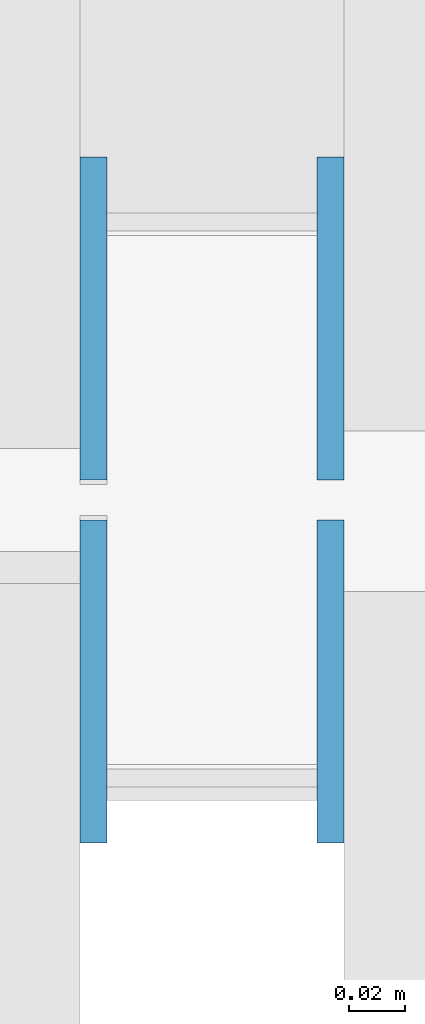
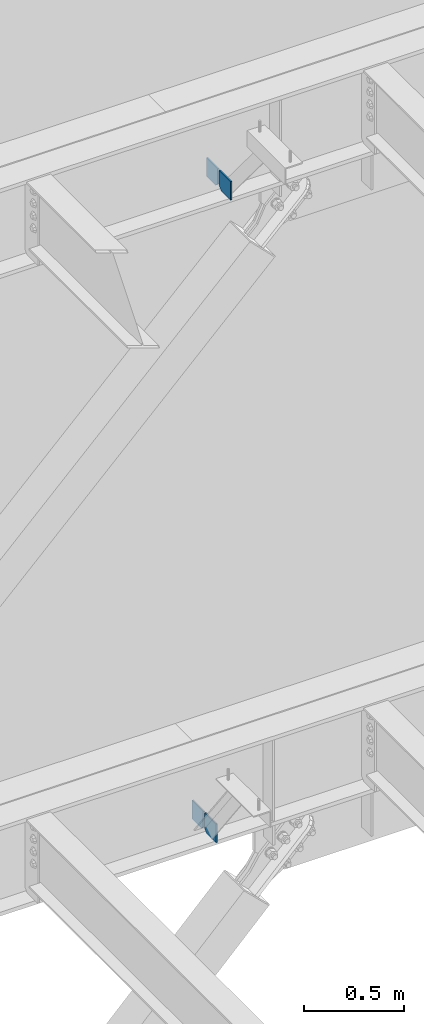
# One storey, part 516 of 1179: 4 columns, 2 elements without a shape of their own.
"""IFC2X3 building model written with IfcOpenShell, lengths in millimetres."""

from ifc_helpers import new_model, si_unit, frame, origin_with_axes, place, context, subcontext, project, spatial, faceted_brep, material, type_object, element, aggregate, save


model = new_model("IFC2X3")

# Units and contexts
model_context = context("Model", 3, precision=1e-05, world=origin_with_axes())
body_context = subcontext(model_context, "Body", "Model", "MODEL_VIEW")
ifc_project = project(units=[si_unit("LENGTHUNIT", "METRE", prefix="MILLI"), si_unit("AREAUNIT", "SQUARE_METRE"), si_unit("VOLUMEUNIT", "CUBIC_METRE"), si_unit("MASSUNIT", "GRAM", prefix="KILO"), si_unit("TIMEUNIT", "SECOND"), si_unit("PLANEANGLEUNIT", "RADIAN"), si_unit("SOLIDANGLEUNIT", "STERADIAN"), si_unit("THERMODYNAMICTEMPERATUREUNIT", "DEGREE_CELSIUS"), si_unit("LUMINOUSINTENSITYUNIT", "LUMEN")], contexts=[model_context])

# Site, building, storey
site_placement = place(None, origin_with_axes())
site = spatial("IfcSite", under=ifc_project, at=site_placement, CompositionType="ELEMENT")
building_placement = place(site_placement, origin_with_axes())
building = spatial("IfcBuilding", under=site, at=building_placement, Name="Undefined", CompositionType="ELEMENT")
storey_placement = place(building_placement, origin_with_axes())
storey = spatial("IfcBuildingStorey", under=building, at=storey_placement, Name="Undefined", CompositionType="ELEMENT", Elevation=0.0)

# Assembly, columns
assembly_1_placement = place(storey_placement, origin_with_axes())
assembly_1 = element("IfcElementAssembly", 1, at=assembly_1_placement, inside=storey, Name="BEAM", AssemblyPlace="NOTDEFINED", PredefinedType="RIGID_FRAME")
ifc_material = material(Name="STEEL/A36")
column_type = type_object("IfcColumnType", PredefinedType="NOTDEFINED")
column_1_placement = place(assembly_1_placement, frame((3530.36728739681, 41263.09375, 7488.2375), z_axis=(0.0, -1.0, 0.0), x_axis=(0.0, 0.0, 1.0)))
column_1 = element("IfcColumn", 2, at=column_1_placement, type_object=column_type, material=ifc_material, Name="PLATE", context=body_context, shape_type="Brep", body=[
    faceted_brep([(22.2250000000004, 4.76250000000073, 57.1500000000015), (0.0, 4.76250000000073, 34.9249999999993), (0.0, -4.76250000000073, 34.9249999999993), (22.2250000000004, -4.76250000000073, 57.1500000000015), (114.300000000001, 4.76250000000073, 57.1500000000015), (114.300000000001, 4.76250000000073, -57.1500000000015), (0.0, 4.76250000000073, -57.1500000000015), (114.300000000001, -4.76250000000073, 57.1500000000015), (0.0, -4.76250000000073, -57.1500000000015), (114.300000000001, -4.76250000000073, -57.1500000000015)], [[[0, 1, 2, 3]], [[4, 5, 6, 1, 0]], [[7, 4, 0, 3]], [[8, 9, 7, 3, 2]], [[8, 6, 5, 9]], [[7, 9, 5, 4]], [[6, 8, 2, 1]]]),
])
column_2_placement = place(assembly_1_placement, frame((3530.36728739681, 41134.50625, 7488.2375), z_axis=(0.0, 1.0, 0.0), x_axis=(0.0, 0.0, 1.0)))
column_2 = element("IfcColumn", 3, at=column_2_placement, type_object=column_type, material=ifc_material, Name="PLATE", context=body_context, shape_type="Brep", body=[
    faceted_brep([(22.2250000000004, 4.76250000000073, 57.1500000000015), (0.0, 4.76250000000073, 34.9249999999993), (0.0, -4.76250000000073, 34.9249999999993), (22.2250000000004, -4.76250000000073, 57.1500000000015), (114.300000000001, 4.76250000000073, 57.1500000000015), (114.300000000001, 4.76250000000073, -57.1500000000015), (0.0, 4.76250000000073, -57.1500000000015), (114.300000000001, -4.76250000000073, 57.1500000000015), (0.0, -4.76250000000073, -57.1500000000015), (114.300000000001, -4.76250000000073, -57.1500000000015)], [[[0, 1, 2, 3]], [[4, 5, 6, 1, 0]], [[7, 4, 0, 3]], [[8, 9, 7, 3, 2]], [[8, 6, 5, 9]], [[7, 9, 5, 4]], [[6, 8, 2, 1]]]),
])
aggregate(assembly_1, [column_1, column_2])

assembly_2_placement = place(storey_placement, origin_with_axes())
assembly_2 = element("IfcElementAssembly", 4, at=assembly_2_placement, inside=storey, Name="BEAM", AssemblyPlace="NOTDEFINED", PredefinedType="RIGID_FRAME")
column_3_placement = place(assembly_2_placement, frame((3446.4625, 41263.09375, 3576.6375), z_axis=(0.0, -1.0, 0.0), x_axis=(0.0, 0.0, 1.0)))
column_3 = element("IfcColumn", 5, at=column_3_placement, type_object=column_type, material=ifc_material, Name="PLATE", context=body_context, shape_type="Brep", body=[
    faceted_brep([(19.0500000000002, 4.76250000000073, 57.1500000000015), (0.0, 4.76250000000073, 38.0999999999985), (0.0, -4.76250000000073, 38.0999999999985), (19.0500000000002, -4.76250000000073, 57.1500000000015), (114.300000000001, 4.76250000000073, 57.1500000000015), (114.300000000001, 4.76250000000073, -57.1500000000015), (0.0, 4.76250000000073, -57.1500000000015), (114.300000000001, -4.76250000000073, 57.1500000000015), (0.0, -4.76250000000073, -57.1500000000015), (114.300000000001, -4.76250000000073, -57.1500000000015)], [[[0, 1, 2, 3]], [[4, 5, 6, 1, 0]], [[7, 4, 0, 3]], [[8, 9, 7, 3, 2]], [[8, 6, 5, 9]], [[7, 9, 5, 4]], [[6, 8, 2, 1]]]),
])
column_4_placement = place(assembly_2_placement, frame((3446.4625, 41134.50625, 3576.6375), z_axis=(0.0, 1.0, 0.0), x_axis=(0.0, 0.0, 1.0)))
column_4 = element("IfcColumn", 6, at=column_4_placement, type_object=column_type, material=ifc_material, Name="PLATE", context=body_context, shape_type="Brep", body=[
    faceted_brep([(19.0500000000002, 4.76250000000073, 57.1500000000015), (0.0, 4.76250000000073, 38.0999999999985), (0.0, -4.76250000000073, 38.0999999999985), (19.0500000000002, -4.76250000000073, 57.1500000000015), (114.300000000001, 4.76250000000073, 57.1500000000015), (114.300000000001, 4.76250000000073, -57.1500000000015), (0.0, 4.76250000000073, -57.1500000000015), (114.300000000001, -4.76250000000073, 57.1500000000015), (0.0, -4.76250000000073, -57.1500000000015), (114.300000000001, -4.76250000000073, -57.1500000000015)], [[[0, 1, 2, 3]], [[4, 5, 6, 1, 0]], [[7, 4, 0, 3]], [[8, 9, 7, 3, 2]], [[8, 6, 5, 9]], [[7, 9, 5, 4]], [[6, 8, 2, 1]]]),
])
aggregate(assembly_2, [column_3, column_4])

save(model, "model.ifc")
